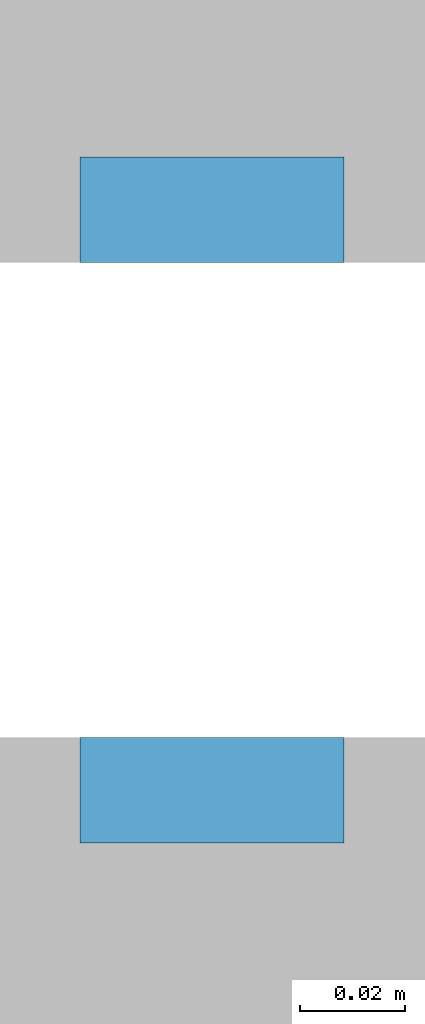
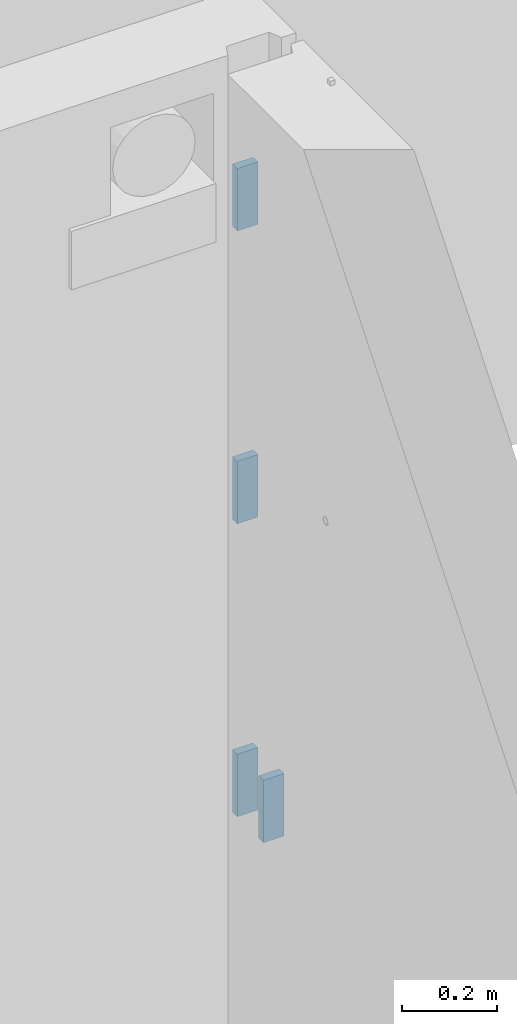
# One storey, part 161 of 264: 4 plates, 6 elements without a shape of their own.
"""IFC2X3 building model written with IfcOpenShell, lengths in millimetres."""

from ifc_helpers import new_model, si_unit, frame, origin_with_axes, place, context, subcontext, project, spatial, faceted_brep, material, type_object, element, aggregate, save


model = new_model("IFC2X3")

# Units and contexts
model_context = context("Model", 3, precision=1e-05, world=origin_with_axes())
body_context = subcontext(model_context, "Body", "Model", "MODEL_VIEW")
ifc_project = project(units=[si_unit("LENGTHUNIT", "METRE", prefix="MILLI"), si_unit("AREAUNIT", "SQUARE_METRE"), si_unit("VOLUMEUNIT", "CUBIC_METRE"), si_unit("MASSUNIT", "GRAM", prefix="KILO"), si_unit("TIMEUNIT", "SECOND"), si_unit("PLANEANGLEUNIT", "RADIAN"), si_unit("SOLIDANGLEUNIT", "STERADIAN"), si_unit("THERMODYNAMICTEMPERATUREUNIT", "DEGREE_CELSIUS"), si_unit("LUMINOUSINTENSITYUNIT", "LUMEN")], contexts=[model_context])

# Site, building, storey
site_placement = place(None, origin_with_axes())
site = spatial("IfcSite", under=ifc_project, at=site_placement, CompositionType="ELEMENT")
building_placement = place(site_placement, origin_with_axes())
building = spatial("IfcBuilding", under=site, at=building_placement, CompositionType="ELEMENT")
storey_placement = place(building_placement, origin_with_axes())
storey = spatial("IfcBuildingStorey", under=building, at=storey_placement, Name="K", CompositionType="ELEMENT", Elevation=0.0)

# Assemblies, plate
assembly_1_placement = place(storey_placement, origin_with_axes())
assembly_1 = element("IfcElementAssembly", 1, at=assembly_1_placement, inside=storey, AssemblyPlace="NOTDEFINED", PredefinedType="REINFORCEMENT_UNIT")
assembly_2_placement = place(assembly_1_placement, origin_with_axes())
assembly_2 = element("IfcElementAssembly", 2, at=assembly_2_placement, Name="Steel Assembly", AssemblyPlace="NOTDEFINED", PredefinedType="RIGID_FRAME")
aggregate(assembly_1, [assembly_2])
ifc_material = material(Name="STEEL/Steel_Undefined")
plate_type = type_object("IfcPlateType", PredefinedType="NOTDEFINED")
plate_1_placement = place(assembly_2_placement, frame((28635.0, 15000.0, 79567.5), z_axis=(0.0, 1.0, 0.0), x_axis=(-1.0, 3.00000001838171e-08, 0.0)))
plate_1 = element("IfcPlate", 3, at=plate_1_placement, type_object=plate_type, material=ifc_material, Name="VL_080", context=body_context, shape_type="Brep", body=[
    faceted_brep([(0.0, -80.0, 0.0), (0.0, -80.0, 20.0), (0.0, 80.0, 20.0), (0.0, 80.0, 0.0), (50.0, -80.0, 20.0), (50.0, 80.0, 20.0), (50.0, -80.0, 0.0), (50.0, 80.0, 0.0)], [[[0, 1, 2, 3]], [[1, 4, 5, 2]], [[4, 6, 7, 5]], [[6, 0, 3, 7]], [[5, 7, 3, 2]], [[6, 4, 1, 0]]]),
])
aggregate(assembly_2, [plate_1])

# Assemblies, plates
assembly_3_placement = place(storey_placement, origin_with_axes())
assembly_3 = element("IfcElementAssembly", 4, at=assembly_3_placement, inside=storey, AssemblyPlace="NOTDEFINED", PredefinedType="REINFORCEMENT_UNIT")
assembly_4_placement = place(assembly_3_placement, origin_with_axes())
assembly_4 = element("IfcElementAssembly", 5, at=assembly_4_placement, Name="Steel Assembly", AssemblyPlace="NOTDEFINED", PredefinedType="RIGID_FRAME")
plate_2_placement = place(assembly_4_placement, frame((28585.0, 15130.0, 81067.5), z_axis=(0.0, -1.0, 0.0), x_axis=(1.0, 0.0, 0.0)))
plate_2 = element("IfcPlate", 6, at=plate_2_placement, type_object=plate_type, material=ifc_material, Name="VL_080", context=body_context, shape_type="Brep", body=[
    faceted_brep([(0.0, -80.0, 0.0), (0.0, -80.0, 20.0), (0.0, 80.0, 20.0), (0.0, 80.0, 0.0), (50.0, -80.0, 20.0), (50.0, 80.0, 20.0), (50.0, -80.0, 0.0), (50.0, 80.0, 0.0)], [[[0, 1, 2, 3]], [[1, 4, 5, 2]], [[4, 6, 7, 5]], [[6, 0, 3, 7]], [[5, 7, 3, 2]], [[6, 4, 1, 0]]]),
])
aggregate(assembly_4, [plate_2])
assembly_5_placement = place(assembly_3_placement, origin_with_axes())
assembly_5 = element("IfcElementAssembly", 7, at=assembly_5_placement, Name="Steel Assembly", AssemblyPlace="NOTDEFINED", PredefinedType="RIGID_FRAME")
plate_3_placement = place(assembly_5_placement, frame((28585.0, 15130.0, 80317.5), z_axis=(0.0, -1.0, 0.0), x_axis=(1.0, 0.0, 0.0)))
plate_3 = element("IfcPlate", 8, at=plate_3_placement, type_object=plate_type, material=ifc_material, Name="VL_080", context=body_context, shape_type="Brep", body=[
    faceted_brep([(0.0, -80.0, 0.0), (0.0, -80.0, 20.0), (0.0, 80.0, 20.0), (0.0, 80.0, 0.0), (50.0, -80.0, 20.0), (50.0, 80.0, 20.0), (50.0, -80.0, 0.0), (50.0, 80.0, 0.0)], [[[0, 1, 2, 3]], [[1, 4, 5, 2]], [[4, 6, 7, 5]], [[6, 0, 3, 7]], [[5, 7, 3, 2]], [[6, 4, 1, 0]]]),
])
aggregate(assembly_5, [plate_3])
assembly_6_placement = place(assembly_3_placement, origin_with_axes())
assembly_6 = element("IfcElementAssembly", 9, at=assembly_6_placement, Name="Steel Assembly", AssemblyPlace="NOTDEFINED", PredefinedType="RIGID_FRAME")
aggregate(assembly_3, [assembly_4, assembly_5, assembly_6])
plate_4_placement = place(assembly_6_placement, frame((28585.0, 15130.0, 79567.5), z_axis=(0.0, -1.0, 0.0), x_axis=(1.0, 0.0, 0.0)))
plate_4 = element("IfcPlate", 10, at=plate_4_placement, type_object=plate_type, material=ifc_material, Name="VL_080", context=body_context, shape_type="Brep", body=[
    faceted_brep([(0.0, -80.0, 0.0), (0.0, -80.0, 20.0), (0.0, 80.0, 20.0), (0.0, 80.0, 0.0), (50.0, -80.0, 20.0), (50.0, 80.0, 20.0), (50.0, -80.0, 0.0), (50.0, 80.0, 0.0)], [[[0, 1, 2, 3]], [[1, 4, 5, 2]], [[4, 6, 7, 5]], [[6, 0, 3, 7]], [[5, 7, 3, 2]], [[6, 4, 1, 0]]]),
])
aggregate(assembly_6, [plate_4])

save(model, "model.ifc")
